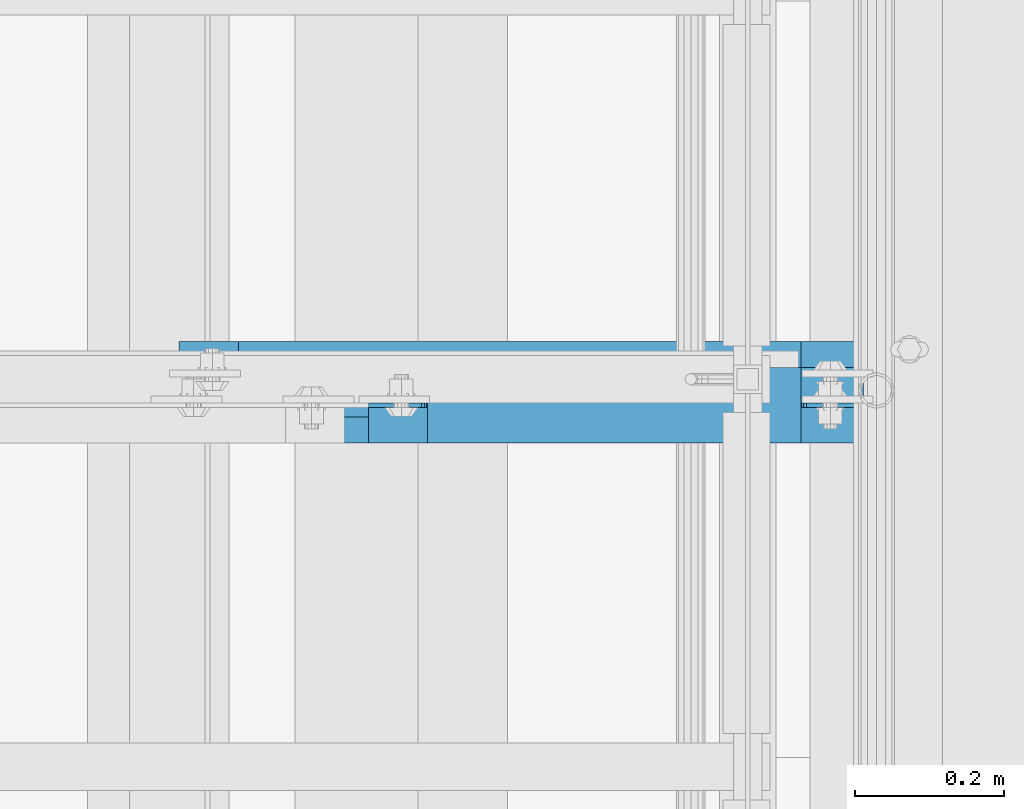
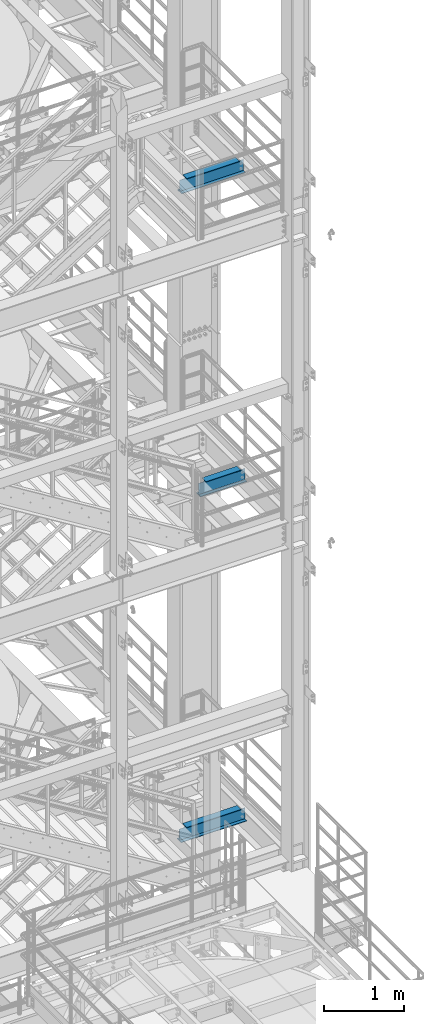
# One storey, part 1201 of 1876: 3 beams, 3 elements without a shape of their own.
"""IFC2X3 building model written with IfcOpenShell, lengths in millimetres."""

import ifcopenshell
import ifcopenshell.guid

model = None  # the IFC model being written
_history = None  # IfcOwnerHistory: only IFC2X3 demands one
_inside = {}  # id of a spatial element -> (the spatial element, [elements in it])
_under = {}  # id of a project, library or spatial element -> (it, [spatial elements below it])
_declared = {}  # id of a project -> (the project, [libraries it declares])
_typed = {}  # id of a type object -> (the type object, [elements of that type])
_made_of = {}  # id of a material, layer set ... -> (it, [elements and type objects made of it])


def new_model(schema):
    """Start an empty IFC model of exactly this schema.

    Asked for "IFC4X3", IfcOpenShell would pick the latest addendum, in which some entities
    have other attributes; the version numbers below select the first issue.
    IFC2X3 requires an IfcOwnerHistory on every rooted entity: one is made here for all.
    """
    global model, _history
    if schema == "IFC4X3":
        model = ifcopenshell.file(schema_version=(4, 3, 0, 0))
    else:
        model = ifcopenshell.file(schema=schema)
    _inside.clear()
    _under.clear()
    _declared.clear()
    _typed.clear()
    _made_of.clear()
    _history = None
    if model.schema == "IFC2X3":
        org = make("IfcOrganization", Name="unknown")
        user = make(
            "IfcPersonAndOrganization",
            ThePerson=make("IfcPerson", FamilyName="unknown"),
            TheOrganization=org,
        )
        app = make(
            "IfcApplication",
            ApplicationDeveloper=org,
            Version="unknown",
            ApplicationFullName="unknown",
            ApplicationIdentifier="unknown",
        )
        _history = make(
            "IfcOwnerHistory",
            OwningUser=user,
            OwningApplication=app,
            ChangeAction="ADDED",
            CreationDate=0,
        )
    return model


def make(cls, **values):
    """One entity of the class cls with the attributes given. An attribute that is None is left unset."""
    return model.create_entity(
        cls, **{name: value for name, value in values.items() if value is not None}
    )


def rooted(cls, **values):
    """An entity with a GlobalId (a new one), such as an element, a storey or a relation."""
    return make(cls, GlobalId=ifcopenshell.guid.new(), OwnerHistory=_history, **values)


def si_unit(unit_type, name, prefix=None):
    """IfcSIUnit, for example si_unit("LENGTHUNIT", "METRE", prefix="MILLI")."""
    return make("IfcSIUnit", UnitType=unit_type, Prefix=prefix, Name=name)


def assignment(units):
    """IfcUnitAssignment: the units of a project."""
    return None if units is None else make("IfcUnitAssignment", Units=units)


def point(xyz):
    """IfcCartesianPoint."""
    return None if xyz is None else make("IfcCartesianPoint", Coordinates=xyz)


def direction(xyz):
    """IfcDirection."""
    return None if xyz is None else make("IfcDirection", DirectionRatios=xyz)


def frame(location, z_axis=None, x_axis=None):
    """IfcAxis2Placement3D, a coordinate frame: its origin and axes. An axis left out is left unset."""
    return make(
        "IfcAxis2Placement3D",
        Location=point(location),
        Axis=direction(z_axis),
        RefDirection=direction(x_axis),
    )


def origin_with_axes():
    """The frame at (0, 0, 0) with the z axis (0, 0, 1) and the x axis (1, 0, 0) written out."""
    return frame((0.0, 0.0, 0.0), z_axis=(0.0, 0.0, 1.0), x_axis=(1.0, 0.0, 0.0))


def place(relative_to, where):
    """IfcLocalPlacement: puts the frame where relative to a parent placement (None: the world)."""
    return make(
        "IfcLocalPlacement", PlacementRelTo=relative_to, RelativePlacement=where
    )


def context(
    kind, dimensions, precision=None, world=None, true_north=None, identifier=None
):
    """IfcGeometricRepresentationContext, for example the 3D "Model" context."""
    return make(
        "IfcGeometricRepresentationContext",
        ContextIdentifier=identifier,
        ContextType=kind,
        CoordinateSpaceDimension=dimensions,
        Precision=precision,
        WorldCoordinateSystem=world,
        TrueNorth=true_north,
    )


def subcontext(parent, identifier, kind, view, scale=None):
    """IfcGeometricRepresentationSubContext, for example "Body" below "Model"."""
    return make(
        "IfcGeometricRepresentationSubContext",
        ContextIdentifier=identifier,
        ContextType=kind,
        ParentContext=parent,
        TargetScale=scale,
        TargetView=view,
    )


def project(units=None, contexts=None):
    """IfcProject with its units and contexts."""
    return rooted(
        "IfcProject",
        Name="project",
        RepresentationContexts=contexts,
        UnitsInContext=assignment(units),
    )


def spatial(cls, under=None, at=None, **own):
    """A site, building, storey or space (cls), placed at a placement, below another one or the project."""
    s = rooted(cls, ObjectPlacement=at, **own)
    if under is not None:
        _under.setdefault(under.id(), (under, []))[1].append(s)
    return s


def faces_of(points, faces, orient=None, outer=None):
    """IfcFace entities. A face is a list of loops; a loop is a list of indices into points, from 0.

    orient and outer hold one flag for each loop. By default every Orientation is true, the
    first loop of a face is its IfcFaceOuterBound and the others are IfcFaceBound.
    """
    made = []
    for i, loops in enumerate(faces):
        bounds = []
        for j, loop in enumerate(loops):
            is_outer = j == 0 if outer is None else outer[i][j]
            bounds.append(
                make(
                    "IfcFaceOuterBound" if is_outer else "IfcFaceBound",
                    Bound=make("IfcPolyLoop", Polygon=[points[k] for k in loop]),
                    Orientation=True if orient is None else orient[i][j],
                )
            )
        made.append(make("IfcFace", Bounds=bounds))
    return made


def faceted_brep(points, faces, orient=None, outer=None, voids=None):
    """IfcFacetedBrep: a solid bounded by flat faces; with voids (closed shells), ...WithVoids."""
    shared = [point(p) for p in points]
    hull = make("IfcClosedShell", CfsFaces=faces_of(shared, faces, orient, outer))
    if voids is None:
        return make("IfcFacetedBrep", Outer=hull)
    return make(
        "IfcFacetedBrepWithVoids",
        Outer=hull,
        Voids=[
            make(cls, CfsFaces=faces_of(shared, fs, o, b)) for cls, fs, o, b in voids
        ],
    )


def shape(context_of_items, identifier, shape_type, items):
    """IfcShapeRepresentation: the items that make up one representation, for example the "Body"."""
    return make(
        "IfcShapeRepresentation",
        ContextOfItems=context_of_items,
        RepresentationIdentifier=identifier,
        RepresentationType=shape_type,
        Items=items,
    )


def material(Name=None, Category=None):
    """IfcMaterial."""
    return make("IfcMaterial", Name=Name, Category=Category)


def made_of(thing, what):
    """Note that an element or type object is made of a material, layer set ...; save() writes the relation."""
    if what is not None:
        _made_of.setdefault(what.id(), (what, []))[1].append(thing)
    return thing


def type_object(cls, material=None, **own):
    """A type object (cls), such as IfcWallType, which elements share."""
    return made_of(rooted(cls, **own), material)


def element(
    cls,
    number,
    at=None,
    inside=None,
    cuts=None,
    type_object=None,
    material=None,
    context=None,
    identifier="Body",
    shape_type=None,
    held_by="IfcProductDefinitionShape",
    body=None,
    shapes=None,
    **own,
):
    """One element of the class cls, such as IfcWall. Its Tag is "e" and its number.

    at: its placement. inside: the storey or other place that contains it. cuts: it is an
    opening in that element (IfcRelVoidsElement). A single representation is given by context,
    identifier, shape_type and body (its items); several are given by shapes. held_by: the class
    of the entity that holds the representations. save() writes the other relations.
    """
    e = rooted(cls, Tag="e%d" % number, ObjectPlacement=at, **own)
    if body is not None:
        shapes = [shape(context, identifier, shape_type, body)]
    if shapes is not None:
        e.Representation = make(held_by, Representations=shapes)
    if inside is not None:
        _inside.setdefault(inside.id(), (inside, []))[1].append(e)
    if cuts is not None:
        rooted(
            "IfcRelVoidsElement", RelatingBuildingElement=cuts, RelatedOpeningElement=e
        )
    if type_object is not None:
        _typed.setdefault(type_object.id(), (type_object, []))[1].append(e)
    return made_of(e, material)


def aggregate(whole, parts):
    """IfcRelAggregates: a whole, such as a stair, and the parts it consists of."""
    return rooted("IfcRelAggregates", RelatingObject=whole, RelatedObjects=parts)


def save(model, path):
    """Write the relations noted so far, then the file.

    IfcRelAggregates (storeys below a building ...), IfcRelContainedInSpatialStructure (elements
    in a storey), IfcRelDefinesByType, IfcRelAssociatesMaterial and IfcRelDeclares: one each for
    every whole, place, type object, material and project.
    """
    for whole, parts in _under.values():
        aggregate(whole, parts)
    for where, things in _inside.values():
        rooted(
            "IfcRelContainedInSpatialStructure",
            RelatedElements=things,
            RelatingStructure=where,
        )
    for kind, things in _typed.values():
        rooted("IfcRelDefinesByType", RelatedObjects=things, RelatingType=kind)
    for what, things in _made_of.values():
        rooted("IfcRelAssociatesMaterial", RelatedObjects=things, RelatingMaterial=what)
    for by, libraries in _declared.values():
        rooted("IfcRelDeclares", RelatingContext=by, RelatedDefinitions=libraries)
    model.write(path)


model = new_model("IFC2X3")

# Units and contexts
model_context = context("Model", 3, precision=1e-05, world=origin_with_axes())
body_context = subcontext(model_context, "Body", "Model", "MODEL_VIEW")
ifc_project = project(units=[si_unit("LENGTHUNIT", "METRE", prefix="MILLI"), si_unit("AREAUNIT", "SQUARE_METRE"), si_unit("VOLUMEUNIT", "CUBIC_METRE"), si_unit("MASSUNIT", "GRAM", prefix="KILO"), si_unit("TIMEUNIT", "SECOND"), si_unit("PLANEANGLEUNIT", "RADIAN"), si_unit("SOLIDANGLEUNIT", "STERADIAN"), si_unit("THERMODYNAMICTEMPERATUREUNIT", "DEGREE_CELSIUS"), si_unit("LUMINOUSINTENSITYUNIT", "LUMEN")], contexts=[model_context])

# Site, building, storey
site_placement = place(None, origin_with_axes())
site = spatial("IfcSite", under=ifc_project, at=site_placement, CompositionType="ELEMENT")
building_placement = place(site_placement, origin_with_axes())
building = spatial("IfcBuilding", under=site, at=building_placement, Name="Undefined", CompositionType="ELEMENT")
storey_placement = place(building_placement, origin_with_axes())
storey = spatial("IfcBuildingStorey", under=building, at=storey_placement, Name="Undefined", CompositionType="ELEMENT", Elevation=0.0)

# Assembly, beam
assembly_1_placement = place(storey_placement, origin_with_axes())
assembly_1 = element("IfcElementAssembly", 1, at=assembly_1_placement, inside=storey, Name="BEAM", AssemblyPlace="NOTDEFINED", PredefinedType="RIGID_FRAME")
ifc_material = material(Name="STEEL/A992")
beam_type = type_object("IfcBeamType", Name="W8X15", PredefinedType="NOTDEFINED")
beam_1_placement = place(assembly_1_placement, frame((6667.5, -5842.0, 17880.0125), z_axis=(0.0, 0.0, 1.0), x_axis=(1.0, 0.0, 0.0)))
beam_1 = element("IfcBeam", 2, at=beam_1_placement, type_object=beam_type, material=ifc_material, Name="BEAM", ObjectType="W8X15", context=body_context, shape_type="Brep", body=[
    faceted_brep([(850.900003051758, -50.8000000000002, 103.1875), (850.900003051758, -50.8000000000002, 95.25), (850.900003051758, -3.17500000000018, 95.25), (850.900003051758, -3.17500000000018, 84.1374998092615), (850.900003051758, 3.17500000000018, 84.1374998092615), (850.900003051758, 3.17500000000018, 95.25), (850.900003051758, 50.8000000000002, 95.25), (850.900003051758, 50.8000000000002, 103.1875), (851.866732974346, -3.17500000000018, 79.2774202912151), (851.866732974346, 3.17500000000018, 79.2774202912151), (854.619746874824, -3.17500000000018, 75.1572438230614), (854.619746874824, 3.17500000000018, 75.1572438230614), (858.739923342978, -3.17500000000018, 72.4042299225839), (858.739923342978, 3.17500000000018, 72.4042299225839), (863.600002861023, -3.17500000000018, 71.4374999999964), (863.600002861023, 3.17500000000018, 71.4374999999964), (935.037499999999, -3.17500000000018, 71.4374999999964), (935.037499999999, 3.17500000000018, 71.4374999999964), (95.25, -50.8000000000002, 103.1875), (95.25, 50.8000000000002, 103.1875), (95.25, 50.8000000000002, 95.25), (95.25, 3.17500000000018, 95.25), (95.25, 3.17500000000018, 87.312499809268), (95.25, -3.17500000000018, 87.312499809268), (95.25, -3.17500000000018, 95.25), (95.25, -50.8000000000002, 95.25), (94.2832700774125, 3.17500000000018, 82.4524202912216), (94.2832700774125, -3.17500000000018, 82.4524202912216), (91.530256176934, 3.17500000000018, 78.332243823068), (91.530256176934, -3.17500000000018, 78.332243823068), (87.4100797087804, 3.17500000000018, 75.5792299225905), (87.4100797087804, -3.17500000000018, 75.5792299225905), (82.5500001907349, 3.17500000000018, 74.6125000000029), (82.5500001907349, -3.17500000000018, 74.6125000000029), (15.875, 3.17500000000018, 74.6125000000029), (15.875, -3.17500000000018, 74.6125000000029), (15.875, 3.17500000000018, -95.25), (15.875, 50.8000000000002, -95.25), (15.875, 50.8000000000002, -103.1875), (15.875, -50.8000000000002, -103.1875), (15.875, -50.8000000000002, -95.25), (15.875, -3.17500000000018, -95.25), (935.037499999999, 3.17500000000018, -95.25), (935.037499999999, 50.8000000000002, -95.25), (935.037499999999, 50.8000000000002, -103.1875), (935.037499999999, -50.8000000000002, -103.1875), (935.037499999999, -50.8000000000002, -95.25), (935.037499999999, -3.17500000000018, -95.25)], [[[0, 1, 2, 3, 4, 5, 6, 7]], [[8, 9, 4, 3]], [[10, 11, 9, 8]], [[12, 13, 11, 10]], [[14, 15, 13, 12]], [[16, 17, 15, 14]], [[18, 19, 20, 21, 22, 23, 24, 25]], [[23, 22, 26, 27]], [[27, 26, 28, 29]], [[29, 28, 30, 31]], [[31, 30, 32, 33]], [[33, 32, 34, 35]], [[36, 37, 38, 39, 40, 41, 35, 34]], [[37, 36, 42, 43]], [[38, 37, 43, 44]], [[39, 38, 44, 45]], [[40, 39, 45, 46]], [[41, 40, 46, 47]], [[12, 10, 8, 3, 2, 24, 23, 27, 29, 31, 33, 35, 41, 47, 16, 14]], [[25, 24, 2, 1]], [[18, 25, 1, 0]], [[19, 18, 0, 7]], [[20, 19, 7, 6]], [[21, 20, 6, 5]], [[42, 36, 34, 32, 30, 28, 26, 22, 21, 5, 4, 9, 11, 13, 15, 17]], [[47, 46, 45, 44, 43, 42, 17, 16]]]),
])
aggregate(assembly_1, [beam_1])

assembly_2_placement = place(storey_placement, origin_with_axes())
assembly_2 = element("IfcElementAssembly", 3, at=assembly_2_placement, inside=storey, Name="BEAM", AssemblyPlace="NOTDEFINED", PredefinedType="RIGID_FRAME")
beam_2_placement = place(assembly_2_placement, frame((6921.5, -5876.925, 13206.4125), z_axis=(0.0, 0.0, 1.0), x_axis=(1.0, 0.0, 0.0)))
beam_2 = element("IfcBeam", 4, at=beam_2_placement, type_object=beam_type, material=ifc_material, Name="BEAM", ObjectType="W8X15", context=body_context, shape_type="Brep", body=[
    faceted_brep([(596.900003051757, -50.8000000000002, 103.1875), (596.900003051757, -50.8000000000002, 95.25), (596.900003051757, -3.17500000000018, 95.25), (596.900003051757, -3.17500000000018, 84.1374998092651), (596.900003051757, 3.17500000000018, 84.1374998092651), (596.900003051757, 3.17500000000018, 95.25), (596.900003051757, 50.8000000000002, 95.25), (596.900003051757, 50.8000000000002, 103.1875), (597.866732974345, -3.17500000000018, 79.2774202912187), (597.866732974345, 3.17500000000018, 79.2774202912187), (600.619746874823, -3.17500000000018, 75.1572438230651), (600.619746874823, 3.17500000000018, 75.1572438230651), (604.739923342977, -3.17500000000018, 72.4042299225875), (604.739923342977, 3.17500000000018, 72.4042299225875), (609.600002861022, -3.17500000000018, 71.4375), (609.600002861022, 3.17500000000018, 71.4375), (681.037499999999, -3.17500000000018, 71.4375), (681.037499999999, 3.17500000000018, 71.4375), (95.25, -50.8000000000002, 103.1875), (95.25, 50.8000000000002, 103.1875), (95.25, 50.8000000000002, 95.25), (95.25, 3.17500000000018, 95.25), (95.25, 3.17500000000018, 87.312499809268), (95.25, -3.17500000000018, 87.312499809268), (95.25, -3.17500000000018, 95.25), (95.25, -50.8000000000002, 95.25), (94.2832700774125, 3.17500000000018, 82.4524202912216), (94.2832700774125, -3.17500000000018, 82.4524202912216), (91.530256176934, 3.17500000000018, 78.332243823068), (91.530256176934, -3.17500000000018, 78.332243823068), (87.4100797087804, 3.17500000000018, 75.5792299225905), (87.4100797087804, -3.17500000000018, 75.5792299225905), (82.5500001907349, 3.17500000000018, 74.6125000000029), (82.5500001907349, -3.17500000000018, 74.6125000000029), (15.875, 3.17500000000018, 74.6125000000029), (15.875, -3.17500000000018, 74.6125000000029), (15.875, 3.17500000000018, -95.25), (15.875, 50.8000000000002, -95.25), (15.875, 50.8000000000002, -103.1875), (15.875, -50.8000000000002, -103.1875), (15.875, -50.8000000000002, -95.25), (15.875, -3.17500000000018, -95.25), (681.037499999999, 3.17500000000018, -95.25), (681.037499999999, 50.8000000000002, -95.25), (681.037499999999, 50.8000000000002, -103.1875), (681.037499999999, -50.8000000000002, -103.1875), (681.037499999999, -50.8000000000002, -95.25), (681.037499999999, -3.17500000000018, -95.25)], [[[0, 1, 2, 3, 4, 5, 6, 7]], [[8, 9, 4, 3]], [[10, 11, 9, 8]], [[12, 13, 11, 10]], [[14, 15, 13, 12]], [[16, 17, 15, 14]], [[18, 19, 20, 21, 22, 23, 24, 25]], [[23, 22, 26, 27]], [[27, 26, 28, 29]], [[29, 28, 30, 31]], [[31, 30, 32, 33]], [[33, 32, 34, 35]], [[36, 37, 38, 39, 40, 41, 35, 34]], [[37, 36, 42, 43]], [[38, 37, 43, 44]], [[39, 38, 44, 45]], [[40, 39, 45, 46]], [[41, 40, 46, 47]], [[12, 10, 8, 3, 2, 24, 23, 27, 29, 31, 33, 35, 41, 47, 16, 14]], [[25, 24, 2, 1]], [[18, 25, 1, 0]], [[19, 18, 0, 7]], [[20, 19, 7, 6]], [[21, 20, 6, 5]], [[42, 36, 34, 32, 30, 28, 26, 22, 21, 5, 4, 9, 11, 13, 15, 17]], [[47, 46, 45, 44, 43, 42, 17, 16]]]),
])
aggregate(assembly_2, [beam_2])

assembly_3_placement = place(storey_placement, origin_with_axes())
assembly_3 = element("IfcElementAssembly", 5, at=assembly_3_placement, inside=storey, Name="BEAM", AssemblyPlace="NOTDEFINED", PredefinedType="RIGID_FRAME")
beam_3_placement = place(assembly_3_placement, frame((6642.496875, -5876.925, 8050.2125), z_axis=(0.0, 0.0, 1.0), x_axis=(1.0, 0.0, 0.0)))
beam_3 = element("IfcBeam", 6, at=beam_3_placement, type_object=beam_type, material=ifc_material, Name="BEAM", ObjectType="W8X15", context=body_context, shape_type="Brep", body=[
    faceted_brep([(875.903128051757, -50.8000000000002, 103.1875), (875.903128051757, -50.8000000000002, 95.25), (875.903128051757, -3.17500000000018, 95.25), (875.903128051757, -3.17500000000018, 84.1374998092651), (875.903128051757, 3.17500000000018, 84.1374998092651), (875.903128051757, 3.17500000000018, 95.25), (875.903128051757, 50.8000000000002, 95.25), (875.903128051757, 50.8000000000002, 103.1875), (876.869857974344, -3.17500000000018, 79.2774202912196), (876.869857974344, 3.17500000000018, 79.2774202912196), (879.622871874823, -3.17500000000018, 75.157243823066), (879.622871874823, 3.17500000000018, 75.157243823066), (883.743048342976, -3.17500000000018, 72.4042299225875), (883.743048342976, 3.17500000000018, 72.4042299225875), (888.603127861022, -3.17500000000018, 71.4375), (888.603127861022, 3.17500000000018, 71.4375), (960.040625000001, -3.17500000000018, 71.4375), (960.040625000001, 3.17500000000018, 71.4375), (95.25, -50.8000000000002, 103.1875), (95.25, 50.8000000000002, 103.1875), (95.25, 50.8000000000002, 95.25), (95.25, 3.17500000000018, 95.25), (95.25, 3.17500000000018, 87.312499809268), (95.25, -3.17500000000018, 87.312499809268), (95.25, -3.17500000000018, 95.25), (95.25, -50.8000000000002, 95.25), (94.2832700774125, 3.17500000000018, 82.4524202912216), (94.2832700774125, -3.17500000000018, 82.4524202912216), (91.530256176934, 3.17500000000018, 78.332243823068), (91.530256176934, -3.17500000000018, 78.332243823068), (87.4100797087804, 3.17500000000018, 75.5792299225905), (87.4100797087804, -3.17500000000018, 75.5792299225905), (82.5500001907349, 3.17500000000018, 74.6125000000029), (82.5500001907349, -3.17500000000018, 74.6125000000029), (15.875, 3.17500000000018, 74.6125000000029), (15.875, -3.17500000000018, 74.6125000000029), (15.875, 3.17500000000018, -95.25), (15.875, 50.8000000000002, -95.25), (15.875, 50.8000000000002, -103.1875), (15.875, -50.8000000000002, -103.1875), (15.875, -50.8000000000002, -95.25), (15.875, -3.17500000000018, -95.25), (960.040625000001, 3.17500000000018, -95.25), (960.040625000001, 50.8000000000002, -95.25), (960.040625000001, 50.8000000000002, -103.1875), (960.040625000001, -50.8000000000002, -103.1875), (960.040625000001, -50.8000000000002, -95.25), (960.040625000001, -3.17500000000018, -95.25)], [[[0, 1, 2, 3, 4, 5, 6, 7]], [[8, 9, 4, 3]], [[10, 11, 9, 8]], [[12, 13, 11, 10]], [[14, 15, 13, 12]], [[16, 17, 15, 14]], [[18, 19, 20, 21, 22, 23, 24, 25]], [[23, 22, 26, 27]], [[27, 26, 28, 29]], [[29, 28, 30, 31]], [[31, 30, 32, 33]], [[33, 32, 34, 35]], [[36, 37, 38, 39, 40, 41, 35, 34]], [[37, 36, 42, 43]], [[38, 37, 43, 44]], [[39, 38, 44, 45]], [[40, 39, 45, 46]], [[41, 40, 46, 47]], [[12, 10, 8, 3, 2, 24, 23, 27, 29, 31, 33, 35, 41, 47, 16, 14]], [[25, 24, 2, 1]], [[18, 25, 1, 0]], [[19, 18, 0, 7]], [[20, 19, 7, 6]], [[21, 20, 6, 5]], [[42, 36, 34, 32, 30, 28, 26, 22, 21, 5, 4, 9, 11, 13, 15, 17]], [[47, 46, 45, 44, 43, 42, 17, 16]]]),
])
aggregate(assembly_3, [beam_3])

save(model, "model.ifc")
